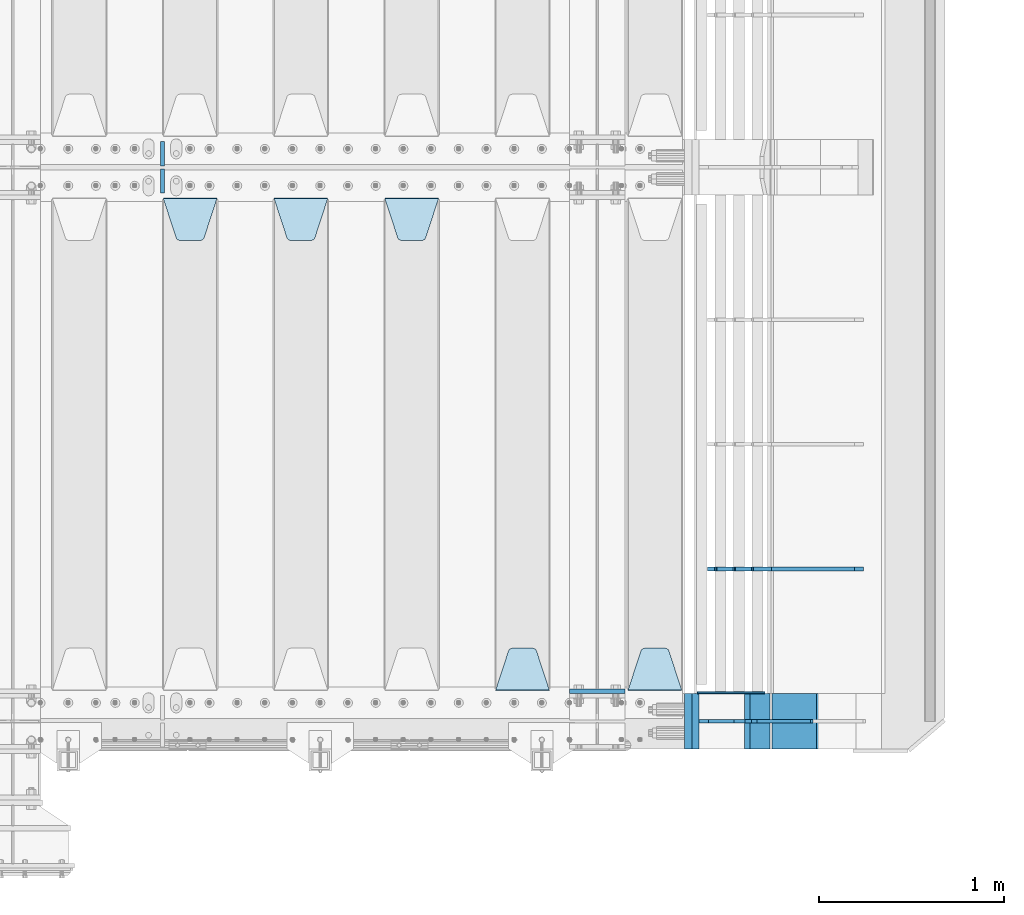
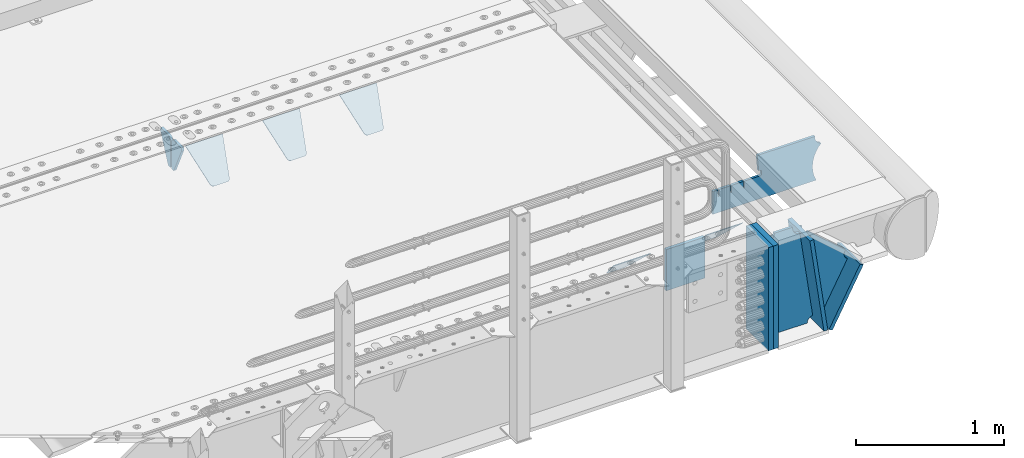
# One storey, part 169 of 193: 16 plates.
"""IFC2X3 building model written with IfcOpenShell, lengths in millimetres."""

from ifc_helpers import new_model, si_unit, frame, origin_with_axes, place, context, subcontext, project, spatial, faceted_brep, material, type_object, element, save


model = new_model("IFC2X3")

# Units and contexts
model_context = context("Model", 3, precision=1e-05, world=origin_with_axes())
body_context = subcontext(model_context, "Body", "Model", "MODEL_VIEW")
ifc_project = project(units=[si_unit("LENGTHUNIT", "METRE", prefix="MILLI"), si_unit("AREAUNIT", "SQUARE_METRE"), si_unit("VOLUMEUNIT", "CUBIC_METRE"), si_unit("MASSUNIT", "GRAM", prefix="KILO"), si_unit("TIMEUNIT", "SECOND"), si_unit("PLANEANGLEUNIT", "RADIAN"), si_unit("SOLIDANGLEUNIT", "STERADIAN"), si_unit("THERMODYNAMICTEMPERATUREUNIT", "DEGREE_CELSIUS"), si_unit("LUMINOUSINTENSITYUNIT", "LUMEN")], contexts=[model_context])

# Site, building, storey
site_placement = place(None, origin_with_axes())
site = spatial("IfcSite", under=ifc_project, at=site_placement, CompositionType="ELEMENT")
building_placement = place(site_placement, origin_with_axes())
building = spatial("IfcBuilding", under=site, at=building_placement, Name="Standard", CompositionType="ELEMENT")
storey_placement = place(building_placement, origin_with_axes())
storey = spatial("IfcBuildingStorey", under=building, at=storey_placement, Name="Undefined", CompositionType="ELEMENT", Elevation=0.0)

# Plates
ifc_material_1 = material(Name="STEEL/S355N")
plate_type_1 = type_object("IfcPlateType", PredefinedType="NOTDEFINED")
plate_1_placement = place(storey_placement, frame((-29045.0, 24162.5, -340.000000000044), z_axis=(0.0, 0.0, 1.0), x_axis=(1.0, 0.0, 0.0)))
element("IfcPlate", 1, at=plate_1_placement, inside=storey, type_object=plate_type_1, material=ifc_material_1, context=body_context, shape_type="Brep", body=[
    faceted_brep([(0.0, -12.5, 0.0), (9.27684595808387e-10, -12.5, 340.0), (9.27684595808387e-10, 12.5, 340.0), (0.0, 12.5, 0.0), (300.0, -12.5, 340.0), (300.0, 12.5, 340.0), (300.0, -12.5, 0.0), (300.0, 12.5, 0.0)], [[[0, 1, 2, 3]], [[1, 4, 5, 2]], [[4, 6, 7, 5]], [[6, 0, 3, 7]], [[5, 7, 3, 2]], [[6, 4, 1, 0]]]),
])
plate_type_2 = type_object("IfcPlateType", PredefinedType="NOTDEFINED")
plate_2_placement = place(storey_placement, frame((-28438.0, 24168.232233047, -1.76776695296758), z_axis=(0.0, 0.707106781186547, -0.707106781186548), x_axis=(-1.0, 0.0, 0.0)))
element("IfcPlate", 2, at=plate_2_placement, inside=storey, type_object=plate_type_2, material=ifc_material_1, context=body_context, shape_type="Brep", body=[
    faceted_brep([(0.0, -2.5, 0.0), (69.345504679477, -2.50000000000364, 300.171731424831), (69.345504679477, 2.49999999999636, 300.171731424831), (0.0, 2.5, 0.0), (70.9274061199576, -2.50000000000364, 304.897442415397), (70.9274061199576, 2.49999999999636, 304.897442415397), (73.3818627772307, -2.50000000000364, 309.234538108529), (73.3818627772307, 2.49999999999636, 309.234538108529), (76.6187032999551, -2.50000000000728, 313.023683126103), (76.6187032999551, 2.49999999999636, 313.023683126103), (80.5190132704993, -2.50000000000364, 316.125672595372), (80.5190132704993, 2.49999999999636, 316.125672595368), (84.9395038596849, -2.50000000000364, 318.426546230472), (84.9395038596849, 2.49999999999636, 318.426546230476), (89.7177759439219, -2.50000000000364, 319.841774983273), (89.7177759439219, 2.49999999999636, 319.841774983277), (94.678286292652, -2.50000000000364, 320.319366455074), (94.678286292652, 2.49999999999636, 320.319366455074), (195.321713707348, -2.50000000000364, 320.319366455074), (195.321713707348, 2.49999999999636, 320.319366455074), (200.282224056078, -2.50000000000364, 319.841774983273), (200.282224056078, 2.49999999999636, 319.841774983277), (205.060496140315, -2.50000000000364, 318.426546230472), (205.060496140315, 2.49999999999636, 318.426546230472), (209.480986729501, -2.50000000000364, 316.125672595372), (209.480986729501, 2.49999999999636, 316.125672595368), (213.381296700045, -2.50000000000728, 313.023683126103), (213.381296700045, 2.49999999999272, 313.023683126103), (216.618137222769, -2.50000000000364, 309.234538108525), (216.618137222769, 2.49999999999636, 309.234538108522), (219.072593880042, -2.50000000000364, 304.897442415397), (219.072593880042, 2.49999999999636, 304.897442415397), (220.654495320523, -2.50000000000364, 300.171731424831), (220.654495320523, 2.49999999999636, 300.171731424831), (290.0, -2.50000000000364, 0.0), (290.0, 2.49999999999636, 0.0)], [[[0, 1, 2, 3]], [[1, 4, 5, 2]], [[4, 6, 7, 5]], [[6, 8, 9, 7]], [[8, 10, 11, 9]], [[10, 12, 13, 11]], [[12, 14, 15, 13]], [[14, 16, 17, 15]], [[16, 18, 19, 17]], [[18, 20, 21, 19]], [[20, 22, 23, 21]], [[22, 24, 25, 23]], [[24, 26, 27, 25]], [[26, 28, 29, 27]], [[28, 30, 31, 29]], [[30, 32, 33, 31]], [[32, 34, 35, 33]], [[34, 0, 3, 35]], [[5, 7, 9, 11, 13, 15, 17, 19, 21, 23, 25, 27, 29, 31, 33, 35, 3, 2]], [[34, 32, 30, 28, 26, 24, 22, 20, 18, 16, 14, 12, 10, 8, 6, 4, 1, 0]]]),
])
plate_3_placement = place(storey_placement, frame((-29155.0, 24168.232233047, -1.76776695296758), z_axis=(0.0, 0.707106781186547, -0.707106781186548), x_axis=(-1.0, 0.0, 0.0)))
element("IfcPlate", 3, at=plate_3_placement, inside=storey, type_object=plate_type_2, material=ifc_material_1, context=body_context, shape_type="Brep", body=[
    faceted_brep([(0.0, -2.5, 0.0), (69.345504679477, -2.50000000000364, 300.171731424831), (69.345504679477, 2.49999999999636, 300.171731424831), (0.0, 2.5, 0.0), (70.9274061199576, -2.50000000000364, 304.897442415397), (70.9274061199576, 2.49999999999636, 304.897442415397), (73.3818627772307, -2.50000000000364, 309.234538108529), (73.3818627772307, 2.49999999999636, 309.234538108529), (76.6187032999551, -2.50000000000728, 313.023683126103), (76.6187032999551, 2.49999999999636, 313.023683126103), (80.5190132704993, -2.50000000000364, 316.125672595372), (80.5190132704993, 2.49999999999636, 316.125672595368), (84.9395038596849, -2.50000000000364, 318.426546230472), (84.9395038596849, 2.49999999999636, 318.426546230476), (89.7177759439219, -2.50000000000364, 319.841774983273), (89.7177759439219, 2.49999999999636, 319.841774983277), (94.678286292652, -2.50000000000364, 320.319366455074), (94.678286292652, 2.49999999999636, 320.319366455074), (195.321713707348, -2.50000000000364, 320.319366455074), (195.321713707348, 2.49999999999636, 320.319366455074), (200.282224056078, -2.50000000000364, 319.841774983273), (200.282224056078, 2.49999999999636, 319.841774983277), (205.060496140315, -2.50000000000364, 318.426546230472), (205.060496140315, 2.49999999999636, 318.426546230472), (209.480986729501, -2.50000000000364, 316.125672595372), (209.480986729501, 2.49999999999636, 316.125672595368), (213.381296700045, -2.50000000000728, 313.023683126103), (213.381296700045, 2.49999999999272, 313.023683126103), (216.618137222769, -2.50000000000364, 309.234538108525), (216.618137222769, 2.49999999999636, 309.234538108522), (219.072593880042, -2.50000000000364, 304.897442415397), (219.072593880042, 2.49999999999636, 304.897442415397), (220.654495320523, -2.50000000000364, 300.171731424831), (220.654495320523, 2.49999999999636, 300.171731424831), (290.0, -2.50000000000364, 0.0), (290.0, 2.49999999999636, 0.0)], [[[0, 1, 2, 3]], [[1, 4, 5, 2]], [[4, 6, 7, 5]], [[6, 8, 9, 7]], [[8, 10, 11, 9]], [[10, 12, 13, 11]], [[12, 14, 15, 13]], [[14, 16, 17, 15]], [[16, 18, 19, 17]], [[18, 20, 21, 19]], [[20, 22, 23, 21]], [[22, 24, 25, 23]], [[24, 26, 27, 25]], [[26, 28, 29, 27]], [[28, 30, 31, 29]], [[30, 32, 33, 31]], [[32, 34, 35, 33]], [[34, 0, 3, 35]], [[5, 7, 9, 11, 13, 15, 17, 19, 21, 23, 25, 27, 29, 31, 33, 35, 3, 2]], [[34, 32, 30, 28, 26, 24, 22, 20, 18, 16, 14, 12, 10, 8, 6, 4, 1, 0]]]),
])
plate_4_placement = place(storey_placement, frame((-30045.0, 26831.767766956, -1.76776695296758), z_axis=(0.0, -0.707106781186547, -0.707106781186548), x_axis=(1.0, 0.0, 0.0)))
element("IfcPlate", 4, at=plate_4_placement, inside=storey, type_object=plate_type_2, material=ifc_material_1, context=body_context, shape_type="Brep", body=[
    faceted_brep([(0.0, -2.5, 0.0), (69.345504679477, -2.50000000000364, 300.171731424831), (69.345504679477, 2.49999999999636, 300.171731424831), (0.0, 2.5, 0.0), (70.9274061199576, -2.50000000000364, 304.897442415397), (70.9274061199576, 2.49999999999636, 304.897442415397), (73.3818627772307, -2.50000000000364, 309.234538108529), (73.3818627772307, 2.49999999999636, 309.234538108529), (76.6187032999551, -2.50000000000728, 313.023683126103), (76.6187032999551, 2.49999999999636, 313.023683126103), (80.5190132704993, -2.50000000000364, 316.125672595372), (80.5190132704993, 2.49999999999636, 316.125672595368), (84.9395038596849, -2.50000000000364, 318.426546230472), (84.9395038596849, 2.49999999999636, 318.426546230476), (89.7177759439219, -2.50000000000364, 319.841774983273), (89.7177759439219, 2.49999999999636, 319.841774983277), (94.678286292652, -2.50000000000364, 320.319366455074), (94.678286292652, 2.49999999999636, 320.319366455074), (195.321713707348, -2.50000000000364, 320.319366455074), (195.321713707348, 2.49999999999636, 320.319366455074), (200.282224056078, -2.50000000000364, 319.841774983273), (200.282224056078, 2.49999999999636, 319.841774983277), (205.060496140315, -2.50000000000364, 318.426546230472), (205.060496140315, 2.49999999999636, 318.426546230472), (209.480986729501, -2.50000000000364, 316.125672595372), (209.480986729501, 2.49999999999636, 316.125672595368), (213.381296700045, -2.50000000000728, 313.023683126103), (213.381296700045, 2.49999999999272, 313.023683126103), (216.618137222769, -2.50000000000364, 309.234538108525), (216.618137222769, 2.49999999999636, 309.234538108522), (219.072593880042, -2.50000000000364, 304.897442415397), (219.072593880042, 2.49999999999636, 304.897442415397), (220.654495320523, -2.50000000000364, 300.171731424831), (220.654495320523, 2.49999999999636, 300.171731424831), (290.0, -2.50000000000364, 0.0), (290.0, 2.49999999999636, 0.0)], [[[0, 1, 2, 3]], [[1, 4, 5, 2]], [[4, 6, 7, 5]], [[6, 8, 9, 7]], [[8, 10, 11, 9]], [[10, 12, 13, 11]], [[12, 14, 15, 13]], [[14, 16, 17, 15]], [[16, 18, 19, 17]], [[18, 20, 21, 19]], [[20, 22, 23, 21]], [[22, 24, 25, 23]], [[24, 26, 27, 25]], [[26, 28, 29, 27]], [[28, 30, 31, 29]], [[30, 32, 33, 31]], [[32, 34, 35, 33]], [[34, 0, 3, 35]], [[5, 7, 9, 11, 13, 15, 17, 19, 21, 23, 25, 27, 29, 31, 33, 35, 3, 2]], [[34, 32, 30, 28, 26, 24, 22, 20, 18, 16, 14, 12, 10, 8, 6, 4, 1, 0]]]),
])
plate_5_placement = place(storey_placement, frame((-30645.0, 26831.767766956, -1.76776695296758), z_axis=(0.0, -0.707106781186547, -0.707106781186548), x_axis=(1.0, 0.0, 0.0)))
element("IfcPlate", 5, at=plate_5_placement, inside=storey, type_object=plate_type_2, material=ifc_material_1, context=body_context, shape_type="Brep", body=[
    faceted_brep([(0.0, -2.5, 0.0), (69.345504679477, -2.50000000000364, 300.171731424831), (69.345504679477, 2.49999999999636, 300.171731424831), (0.0, 2.5, 0.0), (70.9274061199576, -2.50000000000364, 304.897442415397), (70.9274061199576, 2.49999999999636, 304.897442415397), (73.3818627772307, -2.50000000000364, 309.234538108529), (73.3818627772307, 2.49999999999636, 309.234538108529), (76.6187032999551, -2.50000000000728, 313.023683126103), (76.6187032999551, 2.49999999999636, 313.023683126103), (80.5190132704993, -2.50000000000364, 316.125672595372), (80.5190132704993, 2.49999999999636, 316.125672595368), (84.9395038596849, -2.50000000000364, 318.426546230472), (84.9395038596849, 2.49999999999636, 318.426546230476), (89.7177759439219, -2.50000000000364, 319.841774983273), (89.7177759439219, 2.49999999999636, 319.841774983277), (94.678286292652, -2.50000000000364, 320.319366455074), (94.678286292652, 2.49999999999636, 320.319366455074), (195.321713707348, -2.50000000000364, 320.319366455074), (195.321713707348, 2.49999999999636, 320.319366455074), (200.282224056078, -2.50000000000364, 319.841774983273), (200.282224056078, 2.49999999999636, 319.841774983277), (205.060496140315, -2.50000000000364, 318.426546230472), (205.060496140315, 2.49999999999636, 318.426546230472), (209.480986729501, -2.50000000000364, 316.125672595372), (209.480986729501, 2.49999999999636, 316.125672595368), (213.381296700045, -2.50000000000728, 313.023683126103), (213.381296700045, 2.49999999999272, 313.023683126103), (216.618137222769, -2.50000000000364, 309.234538108525), (216.618137222769, 2.49999999999636, 309.234538108522), (219.072593880042, -2.50000000000364, 304.897442415397), (219.072593880042, 2.49999999999636, 304.897442415397), (220.654495320523, -2.50000000000364, 300.171731424831), (220.654495320523, 2.49999999999636, 300.171731424831), (290.0, -2.50000000000364, 0.0), (290.0, 2.49999999999636, 0.0)], [[[0, 1, 2, 3]], [[1, 4, 5, 2]], [[4, 6, 7, 5]], [[6, 8, 9, 7]], [[8, 10, 11, 9]], [[10, 12, 13, 11]], [[12, 14, 15, 13]], [[14, 16, 17, 15]], [[16, 18, 19, 17]], [[18, 20, 21, 19]], [[20, 22, 23, 21]], [[22, 24, 25, 23]], [[24, 26, 27, 25]], [[26, 28, 29, 27]], [[28, 30, 31, 29]], [[30, 32, 33, 31]], [[32, 34, 35, 33]], [[34, 0, 3, 35]], [[5, 7, 9, 11, 13, 15, 17, 19, 21, 23, 25, 27, 29, 31, 33, 35, 3, 2]], [[34, 32, 30, 28, 26, 24, 22, 20, 18, 16, 14, 12, 10, 8, 6, 4, 1, 0]]]),
])
plate_6_placement = place(storey_placement, frame((-31245.0, 26831.767766956, -1.76776695296758), z_axis=(0.0, -0.707106781186547, -0.707106781186548), x_axis=(1.0, 0.0, 0.0)))
element("IfcPlate", 6, at=plate_6_placement, inside=storey, type_object=plate_type_2, material=ifc_material_1, context=body_context, shape_type="Brep", body=[
    faceted_brep([(0.0, -2.5, 0.0), (69.345504679477, -2.50000000000364, 300.171731424831), (69.345504679477, 2.49999999999636, 300.171731424831), (0.0, 2.5, 0.0), (70.9274061199576, -2.50000000000364, 304.897442415397), (70.9274061199576, 2.49999999999636, 304.897442415397), (73.3818627772307, -2.50000000000364, 309.234538108529), (73.3818627772307, 2.49999999999636, 309.234538108529), (76.6187032999551, -2.50000000000728, 313.023683126103), (76.6187032999551, 2.49999999999636, 313.023683126103), (80.5190132704993, -2.50000000000364, 316.125672595372), (80.5190132704993, 2.49999999999636, 316.125672595368), (84.9395038596849, -2.50000000000364, 318.426546230472), (84.9395038596849, 2.49999999999636, 318.426546230476), (89.7177759439219, -2.50000000000364, 319.841774983273), (89.7177759439219, 2.49999999999636, 319.841774983277), (94.678286292652, -2.50000000000364, 320.319366455074), (94.678286292652, 2.49999999999636, 320.319366455074), (195.321713707348, -2.50000000000364, 320.319366455074), (195.321713707348, 2.49999999999636, 320.319366455074), (200.282224056078, -2.50000000000364, 319.841774983273), (200.282224056078, 2.49999999999636, 319.841774983277), (205.060496140315, -2.50000000000364, 318.426546230472), (205.060496140315, 2.49999999999636, 318.426546230472), (209.480986729501, -2.50000000000364, 316.125672595372), (209.480986729501, 2.49999999999636, 316.125672595368), (213.381296700045, -2.50000000000728, 313.023683126103), (213.381296700045, 2.49999999999272, 313.023683126103), (216.618137222769, -2.50000000000364, 309.234538108525), (216.618137222769, 2.49999999999636, 309.234538108522), (219.072593880042, -2.50000000000364, 304.897442415397), (219.072593880042, 2.49999999999636, 304.897442415397), (220.654495320523, -2.50000000000364, 300.171731424831), (220.654495320523, 2.49999999999636, 300.171731424831), (290.0, -2.50000000000364, 0.0), (290.0, 2.49999999999636, 0.0)], [[[0, 1, 2, 3]], [[1, 4, 5, 2]], [[4, 6, 7, 5]], [[6, 8, 9, 7]], [[8, 10, 11, 9]], [[10, 12, 13, 11]], [[12, 14, 15, 13]], [[14, 16, 17, 15]], [[16, 18, 19, 17]], [[18, 20, 21, 19]], [[20, 22, 23, 21]], [[22, 24, 25, 23]], [[24, 26, 27, 25]], [[26, 28, 29, 27]], [[28, 30, 31, 29]], [[30, 32, 33, 31]], [[32, 34, 35, 33]], [[34, 0, 3, 35]], [[5, 7, 9, 11, 13, 15, 17, 19, 21, 23, 25, 27, 29, 31, 33, 35, 3, 2]], [[34, 32, 30, 28, 26, 24, 22, 20, 18, 16, 14, 12, 10, 8, 6, 4, 1, 0]]]),
])
plate_type_3 = type_object("IfcPlateType", PredefinedType="NOTDEFINED")
for number, where, z_axis, x_axis in (
    (7, (-31250.0, 27140.0, -30.0), (0.0, 0.0, -1.0), (0.0, -1.0, 0.0)),
    (8, (-31250.0, 26860.0, -30.0), (0.0, 0.0, -1.0), (0.0, 1.0, 0.0)),
):
    element("IfcPlate", number, at=place(storey_placement, frame(where, z_axis=z_axis, x_axis=x_axis)), inside=storey, type_object=plate_type_3, material=ifc_material_1, context=body_context, shape_type="Brep", body=[
        faceted_brep([(0.0, -10.0, 0.0), (0.0, -10.0, 30.0), (0.0, 10.0, 30.0), (0.0, 10.0, 0.0), (102.0, -10.0, 250.0), (102.0, 10.0, 250.0), (132.0, -10.0, 250.0), (132.0, 10.0, 250.0), (132.0, -10.0, 30.0), (132.0, 10.0, 30.0), (131.544232590368, -10.0, 24.790554669992), (131.544232590368, 10.0, 24.790554669992), (130.190778623579, -10.0, 19.7393957002299), (130.190778623579, 10.0, 19.7393957002299), (127.980762113533, -10.0, 15.0), (127.980762113533, 10.0, 15.0), (124.98133329357, -10.0, 10.7163717094038), (124.98133329357, 10.0, 10.7163717094038), (121.283628290596, -10.0, 7.01866670643062), (121.283628290596, 10.0, 7.01866670643062), (117.0, -10.0, 4.01923788646684), (117.0, 10.0, 4.01923788646684), (112.260604299769, -10.0, 1.80922137642278), (112.260604299769, 10.0, 1.80922137642278), (107.209445330009, -10.0, 0.455767409633722), (107.209445330009, 10.0, 0.455767409633722), (102.0, -10.0, 0.0), (102.0, 10.0, 0.0)], [[[0, 1, 2, 3]], [[1, 4, 5, 2]], [[4, 6, 7, 5]], [[6, 8, 9, 7]], [[8, 10, 11, 9]], [[10, 12, 13, 11]], [[12, 14, 15, 13]], [[14, 16, 17, 15]], [[16, 18, 19, 17]], [[18, 20, 21, 19]], [[20, 22, 23, 21]], [[22, 24, 25, 23]], [[24, 26, 27, 25]], [[26, 0, 3, 27]], [[5, 7, 9, 11, 13, 15, 17, 19, 21, 23, 25, 27, 3, 2]], [[26, 24, 22, 20, 18, 16, 14, 12, 10, 8, 6, 4, 1, 0]]]),
    ])
ifc_material_2 = material()
plate_type_4 = type_object("IfcPlateType", PredefinedType="NOTDEFINED")
for number, where, z_axis, x_axis in (
    (9, (-28363.0011701093, 24150.0, -869.999999999685), (0.0, 0.0, 1.0), (0.0, -1.0, 0.0)),
    (10, (-28403.0, 24150.0, -870.0), (0.0, 0.0, 1.0), (0.0, -1.0, 0.0)),
):
    element("IfcPlate", number, at=place(storey_placement, frame(where, z_axis=z_axis, x_axis=x_axis)), inside=storey, type_object=plate_type_4, material=ifc_material_2, context=body_context, shape_type="Brep", body=[
        faceted_brep([(0.0, -20.0, 0.0), (0.0, -20.0, 850.0), (0.0, 20.0, 850.0), (0.0, 20.0, 0.0), (300.0, -20.0, 850.0), (300.0, 20.0, 850.0), (300.0, -20.0, 0.0), (300.0, 20.0, 0.0)], [[[0, 1, 2, 3]], [[1, 4, 5, 2]], [[4, 6, 7, 5]], [[6, 0, 3, 7]], [[5, 7, 3, 2]], [[6, 4, 1, 0]]]),
    ])
plate_type_5 = type_object("IfcPlateType", PredefinedType="NOTDEFINED")
plate_7_placement = place(storey_placement, frame((-27973.8519322773, 24150.000000001, -862.083788727077), z_axis=(-0.139173011053008, 0.0, 0.990268081377179), x_axis=(0.0, -1.0, 0.0)))
element("IfcPlate", 11, at=plate_7_placement, inside=storey, type_object=plate_type_5, material=ifc_material_1, context=body_context, shape_type="Brep", body=[
    faceted_brep([(1.00408215075731e-09, 14.9994702460535, -0.00376939767284057), (300.0, 15.0, 0.0), (300.0, -15.0, 4.21237841386892), (0.0, -15.0, 4.21237841386892), (0.0, -15.0, 792.0), (300.0, -15.0, 792.0), (300.0, 14.9999999999964, 792.0), (0.0, 14.9999999999964, 792.0)], [[[0, 1, 2, 3]], [[4, 5, 6, 7]], [[4, 7, 0, 3]], [[5, 4, 3, 2]], [[6, 5, 2, 1]], [[7, 6, 1, 0]]]),
])
plate_8_placement = place(storey_placement, frame((-27936.7531990427, 24150.000000001, -867.038754737719), z_axis=(0.469471552246176, 0.0, 0.882947598462992), x_axis=(0.0, -1.0, 0.0)))
element("IfcPlate", 12, at=plate_8_placement, inside=storey, type_object=plate_type_5, material=ifc_material_1, context=body_context, shape_type="Brep", body=[
    faceted_brep([(0.0, -15.0, 0.0), (0.0, -15.0000000000036, 514.999999999996), (0.0, 14.9999999999964, 514.999999999998), (0.0, 15.0, 0.0), (300.0, -15.0000000000036, 514.999999999996), (300.0, 14.9999999999964, 514.999999999998), (300.0, -15.0, 0.0), (300.0, 15.0, 0.0)], [[[0, 1, 2, 3]], [[1, 4, 5, 2]], [[4, 6, 7, 5]], [[6, 0, 3, 7]], [[5, 7, 3, 2]], [[6, 4, 1, 0]]]),
])
plate_type_6 = type_object("IfcPlateType", PredefinedType="NOTDEFINED")
plate_9_placement = place(storey_placement, frame((-27701.9974314966, 24000.000000001, -393.996688204089), z_axis=(-0.658066357015091, 0.0, -0.752959939017267), x_axis=(-0.752959939017268, 0.0, 0.65806635701509)))
element("IfcPlate", 13, at=plate_9_placement, inside=storey, type_object=plate_type_6, material=ifc_material_1, context=body_context, shape_type="Brep", body=[
    faceted_brep([(-11.3595226159632, -10.0, 48.6925173505915), (-112.015767301036, -10.0, 480.154833723627), (-112.015767301036, 10.0, 480.154833723627), (-11.3595226159632, 10.0, 48.6925173505915), (-104.567323293642, -10.0, 482.519601382541), (-104.567323293642, 10.0, 482.519601382541), (-97.5783311599989, -10.0, 486.016090073754), (-97.5783311599989, 10.0, 486.016090073754), (-91.2195220373869, -10.0, 490.558885551654), (-91.2195220373869, 10.0, 490.558885551654), (-85.6462325884277, -10.0, 496.037013784004), (-85.6462325884277, 10.0, 496.037013784004), (447.024482710491, -10.0, 32.810337289633), (447.024482710491, 10.0, 32.810337289633), (441.786973010392, -10.0, 25.5709623937255), (441.786973010392, 10.0, 25.5709623937255), (437.921644570128, -10.0, 17.5149526624118), (437.921644570128, 10.0, 17.5149526624118), (435.551940606492, -10.0, 8.89958500531793), (435.551940606492, 10.0, 8.89958500531793), (434.753540039059, -10.0, -5.20230969414115e-10), (434.753540039059, 10.0, -5.20230969414115e-10), (50.0, -10.0, 0.0), (50.0, 10.0, 0.0), (47.7668538974212, -10.0, 14.7759151575156), (47.7668538974212, 10.0, 14.7759151575156), (41.2668932502784, -10.0, 28.2319592212407), (41.2668932502784, 10.0, 28.2319592212407), (31.0807325300157, -10.0, 39.1661596968261), (31.0807325300157, 10.0, 39.1661596968261), (18.1182591411452, -10.0, 46.6018098971945), (18.1182591411452, 10.0, 46.6018098971945), (3.53735696080548, -10.0, 49.8747140917294), (3.53735696080548, 10.0, 49.8747140917294)], [[[0, 1, 2, 3]], [[1, 4, 5, 2]], [[4, 6, 7, 5]], [[6, 8, 9, 7]], [[8, 10, 11, 9]], [[10, 12, 13, 11]], [[12, 14, 15, 13]], [[14, 16, 17, 15]], [[16, 18, 19, 17]], [[18, 20, 21, 19]], [[20, 22, 23, 21]], [[22, 24, 25, 23]], [[24, 26, 27, 25]], [[26, 28, 29, 27]], [[28, 30, 31, 29]], [[30, 32, 33, 31]], [[32, 0, 3, 33]], [[5, 7, 9, 11, 13, 15, 17, 19, 21, 23, 25, 27, 29, 31, 33, 3, 2]], [[32, 30, 28, 26, 24, 22, 20, 18, 16, 14, 12, 10, 8, 6, 4, 1, 0]]]),
])
plate_type_7 = type_object("IfcPlateType", PredefinedType="NOTDEFINED")
plate_10_placement = place(storey_placement, frame((-28104.0011701109, 24000.0, -30.0000000029351), z_axis=(0.0, 0.0, -1.0), x_axis=(-1.0, 0.0, 0.0)))
element("IfcPlate", 14, at=plate_10_placement, inside=storey, type_object=plate_type_7, material=ifc_material_1, context=body_context, shape_type="Brep", body=[
    faceted_brep([(-9.00602409638668, -10.0, 65.0), (-108.137843376921, -10.0, 780.473130459514), (-108.137843376921, 10.0, 780.473130459514), (-9.00602409638668, 10.0, 65.0), (-94.4157884488377, -10.0, 784.433672138112), (-94.4157884488377, 10.0, 784.433672138112), (-82.3732461236723, -10.0, 792.112074067144), (-82.3732461236723, 10.0, 792.112074067144), (-72.9927947992364, -10.0, 802.881837982249), (-72.9927947992364, 10.0, 802.881837982249), (-67.0398068183713, -10.0, 815.864234368775), (-67.0398068183713, 10.0, 815.864234368775), (-65.0, -10.0, 830.0), (-65.0, 10.0, 830.0), (189.0, -10.0, 830.0), (189.0, 10.0, 830.0), (191.447174185243, -10.0, 814.549150281253), (191.447174185243, 10.0, 814.549150281253), (198.549150281251, -10.0, 800.610737385376), (198.549150281251, 10.0, 800.610737385376), (209.610737385377, -10.0, 789.549150281253), (209.610737385377, 10.0, 789.549150281253), (223.549150281251, -10.0, 782.447174185242), (223.549150281251, 10.0, 782.447174185242), (239.0, -10.0, 780.0), (239.0, 10.0, 780.0), (239.0, -10.0, 50.0), (239.0, 10.0, 50.0), (223.549150281251, -10.0, 47.5528258147577), (223.549150281251, 10.0, 47.5528258147577), (209.610737385377, -10.0, 40.4508497187474), (209.610737385377, 10.0, 40.4508497187474), (198.549150281251, -10.0, 29.3892626146237), (198.549150281251, 10.0, 29.3892626146237), (191.447174185243, -10.0, 15.4508497187474), (191.447174185243, 10.0, 15.4508497187474), (189.0, -10.0, 0.0), (189.0, 10.0, 0.0), (50.4776502774184, -10.0, 0.0), (50.4776502774184, 10.0, 0.0), (47.3830020671812, -10.0, 22.3352870825933), (47.3830020671812, 10.0, 22.3352870825933), (42.8384615202776, -10.0, 37.3040735979326), (42.8384615202776, 10.0, 37.3040735979326), (33.8907372011709, -10.0, 50.1358952937587), (33.8907372011709, 10.0, 50.1358952937587), (21.4156947086703, -10.0, 59.5746840579253), (21.4156947086703, 10.0, 59.5746840579253), (6.63447812067898, -10.0, 64.6965054822873), (6.63447812067898, 10.0, 64.6965054822873)], [[[0, 1, 2, 3]], [[1, 4, 5, 2]], [[4, 6, 7, 5]], [[6, 8, 9, 7]], [[8, 10, 11, 9]], [[10, 12, 13, 11]], [[12, 14, 15, 13]], [[14, 16, 17, 15]], [[16, 18, 19, 17]], [[18, 20, 21, 19]], [[20, 22, 23, 21]], [[22, 24, 25, 23]], [[24, 26, 27, 25]], [[26, 28, 29, 27]], [[28, 30, 31, 29]], [[30, 32, 33, 31]], [[32, 34, 35, 33]], [[34, 36, 37, 35]], [[36, 38, 39, 37]], [[38, 40, 41, 39]], [[40, 42, 43, 41]], [[42, 44, 45, 43]], [[44, 46, 47, 45]], [[46, 48, 49, 47]], [[48, 0, 3, 49]], [[5, 7, 9, 11, 13, 15, 17, 19, 21, 23, 25, 27, 29, 31, 33, 35, 37, 39, 41, 43, 45, 47, 49, 3, 2]], [[48, 46, 44, 42, 40, 38, 36, 34, 32, 30, 28, 26, 24, 22, 20, 18, 16, 14, 12, 10, 8, 6, 4, 1, 0]]]),
])
plate_type_8 = type_object("IfcPlateType", PredefinedType="NOTDEFINED")
plate_11_placement = place(storey_placement, frame((-27457.0817660324, 24824.9992828369, -374.002067436517), z_axis=(0.0, 0.0, 1.0), x_axis=(-1.0, 0.0, 0.0)))
element("IfcPlate", 15, at=plate_11_placement, inside=storey, type_object=plate_type_8, material=ifc_material_1, context=body_context, shape_type="Brep", body=[
    faceted_brep([(801.919404066546, -10.0, 188.0), (801.919404066546, 10.0, 188.0), (801.919404066546, 10.0, 132.002067436952), (801.919404066546, -10.0, 132.002067436952), (793.919404066546, 10.0, 132.002067436952), (793.919404066546, -10.0, 132.002067436952), (793.919404066546, 10.0, 180.002067436952), (793.919404066546, -10.0, 180.002067436952), (793.527856196906, 10.0, 182.474203391951), (793.527856196906, -10.0, 182.474203391951), (792.391540021545, 10.0, 184.704349455291), (792.391540021545, -10.0, 184.704349455291), (790.621686084887, 10.0, 186.474203391951), (790.621686084887, -10.0, 186.474203391951), (788.391540021545, 10.0, 187.610519567313), (788.391540021545, -10.0, 187.610519567313), (785.919404066546, -10.0, 188.002067436952), (785.919404066546, 10.0, 188.0), (841.0, -10.0, 188.0), (841.0, -10.0, 0.0), (841.0, 10.0, 0.0), (841.0, 10.0, 188.0), (33.3619566736015, -10.0, 0.0), (33.3619566736015, 10.0, 0.0), (36.2350612208174, -10.0, 4.68848050267007), (36.2350612208174, 10.0, 4.68848050267007), (51.4877592159428, -10.0, 41.5117508652783), (51.4877592159428, 10.0, 41.5117508652783), (60.792242588137, -10.0, 80.2677133162963), (60.792242588137, 10.0, 80.2677133162963), (63.9194040769726, -10.0, 120.002067436515), (63.9194040769726, 10.0, 120.002067436515), (60.792242588137, -10.0, 159.736421556734), (60.792242588137, 10.0, 159.736421556734), (51.4877592159428, -10.0, 198.492384007752), (51.4877592159428, 10.0, 198.492384007752), (36.2350612208174, -10.0, 235.31565437036), (36.2350612208174, 10.0, 235.31565437036), (15.4097206482074, -10.0, 269.299521518803), (15.4097206482074, 10.0, 269.299521518803), (-3.35474438098754, -10.0, 291.269887256574), (-3.35474438098754, 10.0, 291.269887256574), (-2.36881039375294, -10.0, 291.426043859339), (-2.36881039375294, 10.0, 291.426043859339), (17.1449676604716, -10.0, 301.368810393754), (17.1449676604716, 10.0, 301.368810393754), (32.6311896062471, -10.0, 316.855032339527), (32.6311896062471, 10.0, 316.855032339527), (42.573956140659, -10.0, 336.368810393754), (42.573956140659, 10.0, 336.368810393754), (46.0, -10.0, 358.0), (46.0, 10.0, 358.0), (45.0495205499137, -10.0, 364.001091067617), (45.0495205499137, 10.0, 364.001091067617), (495.040008544922, -10.0, 364.010009765625), (495.040008544922, 10.0, 364.010009765625), (483.600036621094, -10.0, 233.759994506836), (483.600036621094, 10.0, 233.759994506836), (472.0, -10.0, 233.759994506836), (472.0, 10.0, 233.759994506836), (468.909830056251, -10.0, 233.270559669787), (468.909830056251, 10.0, 233.270559669787), (466.122147477075, -10.0, 231.850164450585), (466.122147477075, 10.0, 231.850164450585), (463.909830056251, -10.0, 229.637847029761), (463.909830056251, 10.0, 229.637847029761), (462.489434837047, -10.0, 226.850164450585), (462.489434837047, 10.0, 226.850164450585), (462.0, -10.0, 223.759994506836), (462.0, 10.0, 223.759994506836), (462.0, -10.0, 198.0), (462.0, 10.0, 198.0), (462.489434837047, -10.0, 194.909830056251), (462.489434837047, 10.0, 194.909830056251), (463.909830056251, -10.0, 192.122147477075), (463.909830056251, 10.0, 192.122147477075), (466.122147477075, -10.0, 189.909830056251), (466.122147477075, 10.0, 189.909830056251), (468.909830056251, -10.0, 188.489434837048), (468.909830056251, 10.0, 188.489434837048), (472.0, -10.0, 188.0), (472.0, 10.0, 188.0), (585.919404066546, -10.0, 188.002067436952), (585.919404066546, 10.0, 188.0), (588.391540021545, -10.0, 187.610519567313), (588.391540021545, 10.0, 187.610519567313), (590.621686084887, -10.0, 186.474203391951), (590.621686084887, 10.0, 186.474203391951), (592.391540021545, -10.0, 184.704349455291), (592.391540021545, 10.0, 184.704349455291), (593.527856196906, -10.0, 182.474203391951), (593.527856196906, 10.0, 182.474203391951), (593.919404066546, -10.0, 180.002067436952), (593.919404066546, 10.0, 180.002067436952), (593.919404066546, -10.0, 132.002067436952), (593.919404066546, 10.0, 132.002067436952), (601.919404066546, -10.0, 132.002067436952), (601.919404066546, 10.0, 132.002067436952), (601.919404066546, -10.0, 188.0), (601.919404066546, 10.0, 188.0), (685.919404066546, -10.0, 188.002067436952), (685.919404066546, 10.0, 188.0), (688.391540021545, -10.0, 187.610519567313), (688.391540021545, 10.0, 187.610519567313), (690.621686084887, -10.0, 186.474203391951), (690.621686084887, 10.0, 186.474203391951), (692.391540021545, -10.0, 184.704349455291), (692.391540021545, 10.0, 184.704349455291), (693.527856196906, -10.0, 182.474203391951), (693.527856196906, 10.0, 182.474203391951), (693.919404066546, -10.0, 180.002067436952), (693.919404066546, 10.0, 180.002067436952), (693.919404066546, -10.0, 132.002067436952), (693.919404066546, 10.0, 132.002067436952), (701.919404066546, -10.0, 132.002067436952), (701.919404066546, 10.0, 132.002067436952), (701.919404066546, -10.0, 188.0), (701.919404066546, 10.0, 188.0)], [[[0, 1, 2, 3]], [[3, 2, 4, 5]], [[5, 4, 6, 7]], [[7, 6, 8, 9]], [[9, 8, 10, 11]], [[11, 10, 12, 13]], [[13, 12, 14, 15]], [[16, 15, 14, 17]], [[18, 19, 20, 21]], [[20, 19, 22, 23]], [[22, 24, 25, 23]], [[26, 27, 25, 24]], [[28, 29, 27, 26]], [[30, 31, 29, 28]], [[32, 33, 31, 30]], [[34, 35, 33, 32]], [[36, 37, 35, 34]], [[38, 39, 37, 36]], [[39, 38, 40, 41]], [[40, 42, 43, 41]], [[44, 45, 43, 42]], [[46, 47, 45, 44]], [[48, 49, 47, 46]], [[50, 51, 49, 48]], [[52, 53, 51, 50]], [[54, 55, 53, 52]], [[54, 56, 57, 55]], [[56, 58, 59, 57]], [[58, 60, 61, 59]], [[60, 62, 63, 61]], [[62, 64, 65, 63]], [[64, 66, 67, 65]], [[66, 68, 69, 67]], [[68, 70, 71, 69]], [[70, 72, 73, 71]], [[72, 74, 75, 73]], [[74, 76, 77, 75]], [[76, 78, 79, 77]], [[78, 80, 81, 79]], [[81, 80, 82, 83]], [[82, 84, 85, 83]], [[86, 87, 85, 84]], [[88, 89, 87, 86]], [[90, 91, 89, 88]], [[92, 93, 91, 90]], [[94, 95, 93, 92]], [[96, 97, 95, 94]], [[98, 99, 97, 96]], [[99, 98, 100, 101]], [[100, 102, 103, 101]], [[104, 105, 103, 102]], [[106, 107, 105, 104]], [[108, 109, 107, 106]], [[110, 111, 109, 108]], [[112, 113, 111, 110]], [[114, 115, 113, 112]], [[116, 117, 115, 114]], [[117, 116, 16, 17]], [[12, 10, 8, 6, 4, 2, 1, 21, 20, 23, 25, 27, 29, 31, 33, 35, 37, 39, 41, 43, 45, 47, 49, 51, 53, 55, 57, 59, 61, 63, 65, 67, 69, 71, 73, 75, 77, 79, 81, 83, 85, 87, 89, 91, 93, 95, 97, 99, 101, 103, 105, 107, 109, 111, 113, 115, 117, 17, 14]], [[18, 21, 1, 0]], [[116, 114, 112, 110, 108, 106, 104, 102, 100, 98, 96, 94, 92, 90, 88, 86, 84, 82, 80, 78, 76, 74, 72, 70, 68, 66, 64, 62, 60, 58, 56, 54, 52, 50, 48, 46, 44, 42, 40, 38, 36, 34, 32, 30, 28, 26, 24, 22, 19, 18, 0, 3, 5, 7, 9, 11, 13, 15, 16]]]),
])
plate_type_9 = type_object("IfcPlateType", PredefinedType="NOTDEFINED")
plate_12_placement = place(storey_placement, frame((-27988.001170099, 24155.0, -249.999999999564), z_axis=(-1.0, 0.0, 0.0), x_axis=(0.0, 0.0, 1.0)))
element("IfcPlate", 16, at=plate_12_placement, inside=storey, type_object=plate_type_9, material=ifc_material_1, context=body_context, shape_type="Brep", body=[
    faceted_brep([(0.0, -5.0, 0.0), (0.0, -5.0, 365.0), (0.0, 5.0, 365.0), (0.0, 5.0, 0.0), (80.0, -5.0, 365.0), (80.0, 5.0, 365.0), (80.0, -5.0, 0.0), (80.0, 5.0, 0.0)], [[[0, 1, 2, 3]], [[1, 4, 5, 2]], [[4, 6, 7, 5]], [[6, 0, 3, 7]], [[5, 7, 3, 2]], [[6, 4, 1, 0]]]),
])

save(model, "model.ifc")
